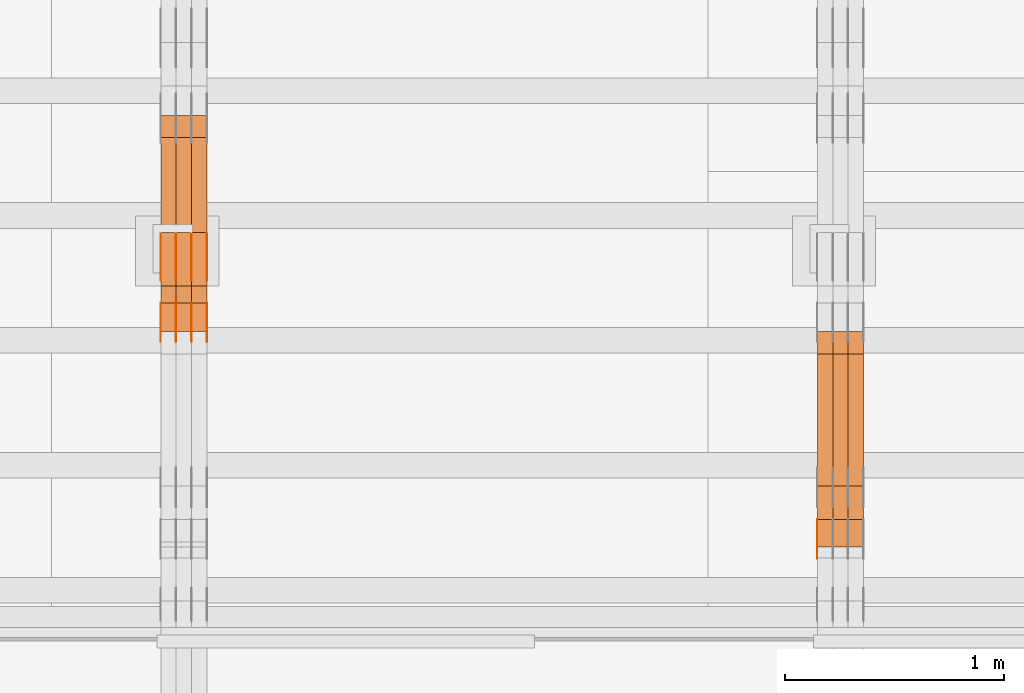
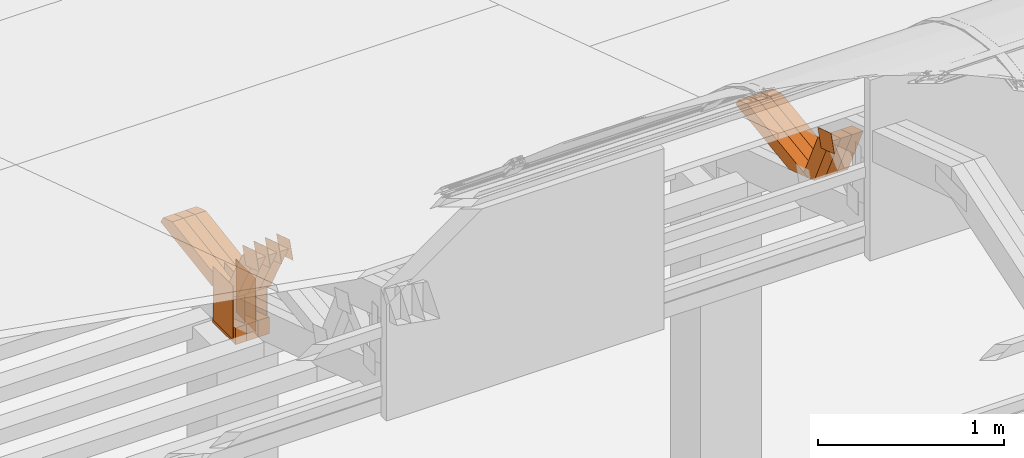
# One storey, part 104 of 385: 28 proxies.
"""IFC2X3 building model written with IfcOpenShell, lengths in millimetres."""

import ifcopenshell
import ifcopenshell.guid

model = None  # the IFC model being written
_history = None  # IfcOwnerHistory: only IFC2X3 demands one
_inside = {}  # id of a spatial element -> (the spatial element, [elements in it])
_under = {}  # id of a project, library or spatial element -> (it, [spatial elements below it])
_declared = {}  # id of a project -> (the project, [libraries it declares])
_typed = {}  # id of a type object -> (the type object, [elements of that type])
_made_of = {}  # id of a material, layer set ... -> (it, [elements and type objects made of it])


def new_model(schema):
    """Start an empty IFC model of exactly this schema.

    Asked for "IFC4X3", IfcOpenShell would pick the latest addendum, in which some entities
    have other attributes; the version numbers below select the first issue.
    IFC2X3 requires an IfcOwnerHistory on every rooted entity: one is made here for all.
    """
    global model, _history
    if schema == "IFC4X3":
        model = ifcopenshell.file(schema_version=(4, 3, 0, 0))
    else:
        model = ifcopenshell.file(schema=schema)
    _inside.clear()
    _under.clear()
    _declared.clear()
    _typed.clear()
    _made_of.clear()
    _history = None
    if model.schema == "IFC2X3":
        org = make("IfcOrganization", Name="unknown")
        user = make(
            "IfcPersonAndOrganization",
            ThePerson=make("IfcPerson", FamilyName="unknown"),
            TheOrganization=org,
        )
        app = make(
            "IfcApplication",
            ApplicationDeveloper=org,
            Version="unknown",
            ApplicationFullName="unknown",
            ApplicationIdentifier="unknown",
        )
        _history = make(
            "IfcOwnerHistory",
            OwningUser=user,
            OwningApplication=app,
            ChangeAction="ADDED",
            CreationDate=0,
        )
    return model


def make(cls, **values):
    """One entity of the class cls with the attributes given. An attribute that is None is left unset."""
    return model.create_entity(
        cls, **{name: value for name, value in values.items() if value is not None}
    )


def entity(cls, *values):
    """Any entity or typed value of the class cls, its attributes in the order of the schema. None: left unset."""
    e = model.create_entity(cls)
    for i, value in enumerate(values):
        if value is not None:
            e[i] = value
    return e


def rooted(cls, **values):
    """An entity with a GlobalId (a new one), such as an element, a storey or a relation."""
    return make(cls, GlobalId=ifcopenshell.guid.new(), OwnerHistory=_history, **values)


def si_unit(unit_type, name, prefix=None):
    """IfcSIUnit, for example si_unit("LENGTHUNIT", "METRE", prefix="MILLI")."""
    return make("IfcSIUnit", UnitType=unit_type, Prefix=prefix, Name=name)


def converted_unit(unit_type, name, factor, base, dimensions=None, offset=None):
    """IfcConversionBasedUnit, such as the inch: factor (a typed value) times the base unit."""
    return make(
        "IfcConversionBasedUnit"
        if offset is None
        else "IfcConversionBasedUnitWithOffset",
        ConversionOffset=offset,
        Dimensions=None
        if dimensions is None
        else entity("IfcDimensionalExponents", *dimensions),
        UnitType=unit_type,
        Name=name,
        ConversionFactor=make(
            "IfcMeasureWithUnit", ValueComponent=factor, UnitComponent=base
        ),
    )


def derived_unit(unit_type, elements):
    """IfcDerivedUnit: a product of units, each with its exponent."""
    return make(
        "IfcDerivedUnit",
        Elements=[
            make("IfcDerivedUnitElement", Unit=unit, Exponent=power)
            for unit, power in elements
        ],
        UnitType=unit_type,
    )


def assignment(units):
    """IfcUnitAssignment: the units of a project."""
    return None if units is None else make("IfcUnitAssignment", Units=units)


def point(xyz):
    """IfcCartesianPoint."""
    return None if xyz is None else make("IfcCartesianPoint", Coordinates=xyz)


def direction(xyz):
    """IfcDirection."""
    return None if xyz is None else make("IfcDirection", DirectionRatios=xyz)


def frame(location, z_axis=None, x_axis=None):
    """IfcAxis2Placement3D, a coordinate frame: its origin and axes. An axis left out is left unset."""
    return make(
        "IfcAxis2Placement3D",
        Location=point(location),
        Axis=direction(z_axis),
        RefDirection=direction(x_axis),
    )


def frame_2d(location, x_axis=None):
    """IfcAxis2Placement2D, a coordinate frame in the plane: its origin and x axis."""
    return make(
        "IfcAxis2Placement2D", Location=point(location), RefDirection=direction(x_axis)
    )


def origin():
    """The frame at (0, 0, 0) with its axes left unset."""
    return frame((0.0, 0.0, 0.0))


def origin_2d_with_axis():
    """The frame at (0, 0) in the plane with the x axis (1, 0) written out."""
    return frame_2d((0.0, 0.0), x_axis=(1.0, 0.0))


def place(relative_to, where):
    """IfcLocalPlacement: puts the frame where relative to a parent placement (None: the world)."""
    return make(
        "IfcLocalPlacement", PlacementRelTo=relative_to, RelativePlacement=where
    )


def context(
    kind, dimensions, precision=None, world=None, true_north=None, identifier=None
):
    """IfcGeometricRepresentationContext, for example the 3D "Model" context."""
    return make(
        "IfcGeometricRepresentationContext",
        ContextIdentifier=identifier,
        ContextType=kind,
        CoordinateSpaceDimension=dimensions,
        Precision=precision,
        WorldCoordinateSystem=world,
        TrueNorth=true_north,
    )


def subcontext(parent, identifier, kind, view, scale=None):
    """IfcGeometricRepresentationSubContext, for example "Body" below "Model"."""
    return make(
        "IfcGeometricRepresentationSubContext",
        ContextIdentifier=identifier,
        ContextType=kind,
        ParentContext=parent,
        TargetScale=scale,
        TargetView=view,
    )


def project(units=None, contexts=None):
    """IfcProject with its units and contexts."""
    return rooted(
        "IfcProject",
        Name="project",
        RepresentationContexts=contexts,
        UnitsInContext=assignment(units),
    )


def spatial(cls, under=None, at=None, **own):
    """A site, building, storey or space (cls), placed at a placement, below another one or the project."""
    s = rooted(cls, ObjectPlacement=at, **own)
    if under is not None:
        _under.setdefault(under.id(), (under, []))[1].append(s)
    return s


def polyline(points):
    """IfcPolyline through the points."""
    return make("IfcPolyline", Points=[point(p) for p in points])


def profile(cls, at=None, kind="AREA", **sizes):
    """A parametric profile (cls). Its sizes go by their IFC names, for example OverallWidth=200.0."""
    return make(cls, ProfileType=kind, Position=at, **sizes)


def rectangle(**sizes):
    """IfcRectangleProfileDef."""
    return profile("IfcRectangleProfileDef", **sizes)


def outline(outer, holes=None, kind="AREA"):
    """IfcArbitraryClosedProfileDef: a profile drawn as a closed curve; with holes, ...WithVoids."""
    if holes is None:
        return make("IfcArbitraryClosedProfileDef", ProfileType=kind, OuterCurve=outer)
    return make(
        "IfcArbitraryProfileDefWithVoids",
        ProfileType=kind,
        OuterCurve=outer,
        InnerCurves=holes,
    )


def extrude(swept, where, along, depth):
    """IfcExtrudedAreaSolid: the profile swept, set in the frame where, extruded along a direction by depth."""
    return make(
        "IfcExtrudedAreaSolid",
        SweptArea=swept,
        Position=where,
        ExtrudedDirection=direction(along),
        Depth=depth,
    )


def shape(context_of_items, identifier, shape_type, items):
    """IfcShapeRepresentation: the items that make up one representation, for example the "Body"."""
    return make(
        "IfcShapeRepresentation",
        ContextOfItems=context_of_items,
        RepresentationIdentifier=identifier,
        RepresentationType=shape_type,
        Items=items,
    )


def source(mapping_origin, context_of_items, identifier, shape_type, items):
    """IfcRepresentationMap: a shape defined once, which mapped items show again and again."""
    return make(
        "IfcRepresentationMap",
        MappingOrigin=mapping_origin,
        MappedRepresentation=shape(context_of_items, identifier, shape_type, items),
    )


def transform(
    local_origin,
    x_axis=None,
    y_axis=None,
    z_axis=None,
    scale=None,
    scale2=None,
    scale3=None,
    uniform=True,
):
    """IfcCartesianTransformationOperator3D, or its non-uniform kind. x_axis, y_axis, z_axis: its Axis1, 2, 3."""
    if uniform:
        return make(
            "IfcCartesianTransformationOperator3D",
            Axis1=direction(x_axis),
            Axis2=direction(y_axis),
            LocalOrigin=point(local_origin),
            Scale=scale,
            Axis3=direction(z_axis),
        )
    return make(
        "IfcCartesianTransformationOperator3DnonUniform",
        Axis1=direction(x_axis),
        Axis2=direction(y_axis),
        LocalOrigin=point(local_origin),
        Scale=scale,
        Axis3=direction(z_axis),
        Scale2=scale2,
        Scale3=scale3,
    )


def mapped(mapping_source, mapping_target):
    """IfcMappedItem: shows the shape of a source again, moved by a transform."""
    return make(
        "IfcMappedItem", MappingSource=mapping_source, MappingTarget=mapping_target
    )


def material(Name=None, Category=None):
    """IfcMaterial."""
    return make("IfcMaterial", Name=Name, Category=Category)


def made_of(thing, what):
    """Note that an element or type object is made of a material, layer set ...; save() writes the relation."""
    if what is not None:
        _made_of.setdefault(what.id(), (what, []))[1].append(thing)
    return thing


def type_object(cls, material=None, **own):
    """A type object (cls), such as IfcWallType, which elements share."""
    return made_of(rooted(cls, **own), material)


def type_shapes(of_type, sources):
    """Give a type object the sources (RepresentationMaps) that its elements show as mapped items."""
    of_type.RepresentationMaps = sources


def element(
    cls,
    number,
    at=None,
    inside=None,
    cuts=None,
    type_object=None,
    material=None,
    context=None,
    identifier="Body",
    shape_type=None,
    held_by="IfcProductDefinitionShape",
    body=None,
    shapes=None,
    **own,
):
    """One element of the class cls, such as IfcWall. Its Tag is "e" and its number.

    at: its placement. inside: the storey or other place that contains it. cuts: it is an
    opening in that element (IfcRelVoidsElement). A single representation is given by context,
    identifier, shape_type and body (its items); several are given by shapes. held_by: the class
    of the entity that holds the representations. save() writes the other relations.
    """
    e = rooted(cls, Tag="e%d" % number, ObjectPlacement=at, **own)
    if body is not None:
        shapes = [shape(context, identifier, shape_type, body)]
    if shapes is not None:
        e.Representation = make(held_by, Representations=shapes)
    if inside is not None:
        _inside.setdefault(inside.id(), (inside, []))[1].append(e)
    if cuts is not None:
        rooted(
            "IfcRelVoidsElement", RelatingBuildingElement=cuts, RelatedOpeningElement=e
        )
    if type_object is not None:
        _typed.setdefault(type_object.id(), (type_object, []))[1].append(e)
    return made_of(e, material)


def aggregate(whole, parts):
    """IfcRelAggregates: a whole, such as a stair, and the parts it consists of."""
    return rooted("IfcRelAggregates", RelatingObject=whole, RelatedObjects=parts)


def save(model, path):
    """Write the relations noted so far, then the file.

    IfcRelAggregates (storeys below a building ...), IfcRelContainedInSpatialStructure (elements
    in a storey), IfcRelDefinesByType, IfcRelAssociatesMaterial and IfcRelDeclares: one each for
    every whole, place, type object, material and project.
    """
    for whole, parts in _under.values():
        aggregate(whole, parts)
    for where, things in _inside.values():
        rooted(
            "IfcRelContainedInSpatialStructure",
            RelatedElements=things,
            RelatingStructure=where,
        )
    for kind, things in _typed.values():
        rooted("IfcRelDefinesByType", RelatedObjects=things, RelatingType=kind)
    for what, things in _made_of.values():
        rooted("IfcRelAssociatesMaterial", RelatedObjects=things, RelatingMaterial=what)
    for by, libraries in _declared.values():
        rooted("IfcRelDeclares", RelatingContext=by, RelatedDefinitions=libraries)
    model.write(path)


model = new_model("IFC2X3")

# Units and contexts
model_context = context("Model", 3, precision=0.01, world=origin(), true_north=direction((6.12303176911189e-17, 1.0)))
body_context = subcontext(model_context, "Body", "Model", "MODEL_VIEW")
ifc_project = project(units=[si_unit("LENGTHUNIT", "METRE", prefix="MILLI"), si_unit("AREAUNIT", "SQUARE_METRE"), si_unit("VOLUMEUNIT", "CUBIC_METRE"), converted_unit("PLANEANGLEUNIT", "DEGREE", entity("IfcRatioMeasure", 0.0174532925199433), si_unit("PLANEANGLEUNIT", "RADIAN"), dimensions=[0, 0, 0, 0, 0, 0, 0]), si_unit("MASSUNIT", "GRAM", prefix="KILO"), derived_unit("MASSDENSITYUNIT", [(si_unit("MASSUNIT", "GRAM", prefix="KILO"), 1), (si_unit("LENGTHUNIT", "METRE"), -3)]), si_unit("TIMEUNIT", "SECOND"), si_unit("FREQUENCYUNIT", "HERTZ"), si_unit("THERMODYNAMICTEMPERATUREUNIT", "DEGREE_CELSIUS"), derived_unit("THERMALTRANSMITTANCEUNIT", [(si_unit("MASSUNIT", "GRAM", prefix="KILO"), 1), (si_unit("THERMODYNAMICTEMPERATUREUNIT", "KELVIN"), -1), (si_unit("TIMEUNIT", "SECOND"), -3)]), derived_unit("VOLUMETRICFLOWRATEUNIT", [(si_unit("LENGTHUNIT", "METRE"), 3), (si_unit("TIMEUNIT", "SECOND"), -1)]), si_unit("ELECTRICCURRENTUNIT", "AMPERE"), si_unit("ELECTRICVOLTAGEUNIT", "VOLT"), si_unit("POWERUNIT", "WATT"), si_unit("FORCEUNIT", "NEWTON", prefix="KILO"), si_unit("ILLUMINANCEUNIT", "LUX"), si_unit("LUMINOUSFLUXUNIT", "LUMEN"), si_unit("LUMINOUSINTENSITYUNIT", "CANDELA"), derived_unit("USERDEFINED", [(si_unit("MASSUNIT", "GRAM", prefix="KILO"), -1), (si_unit("LENGTHUNIT", "METRE"), -2), (si_unit("TIMEUNIT", "SECOND"), 3), (si_unit("LUMINOUSFLUXUNIT", "LUMEN"), 1)]), derived_unit("LINEARVELOCITYUNIT", [(si_unit("LENGTHUNIT", "METRE"), 1), (si_unit("TIMEUNIT", "SECOND"), -1)]), si_unit("PRESSUREUNIT", "PASCAL"), derived_unit("USERDEFINED", [(si_unit("LENGTHUNIT", "METRE"), -2), (si_unit("MASSUNIT", "GRAM", prefix="KILO"), 1), (si_unit("TIMEUNIT", "SECOND"), -2)])], contexts=[model_context])

# Site, building, storey
site_placement = place(None, origin())
site = spatial("IfcSite", under=ifc_project, at=site_placement, CompositionType="ELEMENT")
building_placement = place(site_placement, origin())
building = spatial("IfcBuilding", under=site, at=building_placement, CompositionType="ELEMENT")
storey_placement = place(building_placement, origin())
storey = spatial("IfcBuildingStorey", under=building, at=storey_placement, Name="Default", CompositionType="ELEMENT", Elevation=0.0)

# Proxies
ifc_material_1 = material(Name="IfcSurfaceStyle #200305")
building_element_proxy_type_1 = type_object("IfcBuildingElementProxyType", PredefinedType="NOTDEFINED", material=ifc_material_1)
shared_shape_1 = source(origin(), body_context, "Body", "SweptSolid", [
    extrude(outline(polyline([(-75.0003249421702, -60.0000773549573), (75.0003398116874, -60.0000773549573), (75.0003249421711, 60.0000773549573), (-75.0003398116883, 60.0000773549573), (-75.0003249421702, -60.0000773549573)])), frame((75.0003398116874, 60.0000773549573, 0.0), z_axis=(0.0, 0.0, 1.0), x_axis=(-1.0, 0.0, 0.0)), (0.0, 0.0, 1.0), 1.29999999999999),
])
type_shapes(building_element_proxy_type_1, [shared_shape_1])
proxy_1_placement = place(building_placement, frame((15175.0, 16117.0849050545, 3705.49074668796), z_axis=(-1.0, 0.0, 0.0), x_axis=(0.0, -0.951056516295154, 0.309016994374948)))
element("IfcBuildingElementProxy", 1, at=proxy_1_placement, inside=storey, type_object=building_element_proxy_type_1, material=ifc_material_1, context=body_context, shape_type="MappedRepresentation", body=[
    mapped(shared_shape_1, transform((0.0, 0.0, 0.0), scale=1.0)),
])
ifc_material_2 = material(Name="IfcSurfaceStyle #189970")
building_element_proxy_type_2 = type_object("IfcBuildingElementProxyType", Name="T1-W44 189968", PredefinedType="NOTDEFINED", material=ifc_material_2)
shared_shape_2 = source(origin(), body_context, "Body", "SweptSolid", [
    extrude(outline(polyline([(-184.551057772692, -47.4997984945814), (177.527112951531, -47.4997984945814), (162.630077773546, -0.000452497529500495), (118.068221667048, 47.5000247433462), (-273.674354619433, 47.5000247433462), (-184.551057772692, -47.4997984945814)])), frame((177.527112951531, 47.5002721629815, 0.0), z_axis=(0.0, 0.0, 1.0), x_axis=(-1.0, 0.0, 0.0)), (0.0, 0.0, 1.0), 70.0),
])
type_shapes(building_element_proxy_type_2, [shared_shape_2])
proxy_2_placement = place(building_placement, frame((15385.0, 16220.4899216004, 3388.98238154171), z_axis=(-1.0, 0.0, 0.0), x_axis=(0.0, -0.425335045192995, 0.905035965766374)))
element("IfcBuildingElementProxy", 2, at=proxy_2_placement, inside=storey, type_object=building_element_proxy_type_2, material=ifc_material_2, Name="T1-W44", context=body_context, shape_type="MappedRepresentation", body=[
    mapped(shared_shape_2, transform((0.0, 0.0, 0.0), scale=1.0)),
])
ifc_material_3 = material(Name="IfcSurfaceStyle #189904")
building_element_proxy_type_3 = type_object("IfcBuildingElementProxyType", Name="T1-W44 189902", PredefinedType="NOTDEFINED", material=ifc_material_3)
shared_shape_3 = source(origin(), body_context, "Body", "SweptSolid", [
    extrude(outline(polyline([(-184.551057772692, -47.4997984945814), (177.527112951531, -47.4997984945814), (162.630077773546, -0.000452497529500495), (118.068221667048, 47.5000247433462), (-273.674354619433, 47.5000247433462), (-184.551057772692, -47.4997984945814)])), frame((177.527112951531, 47.5002721629815, 0.0), z_axis=(0.0, 0.0, 1.0), x_axis=(-1.0, 0.0, 0.0)), (0.0, 0.0, 1.0), 70.0),
])
type_shapes(building_element_proxy_type_3, [shared_shape_3])
proxy_3_placement = place(building_placement, frame((15315.0, 16220.4899216004, 3388.98238154171), z_axis=(-1.0, 0.0, 0.0), x_axis=(0.0, -0.425335045192995, 0.905035965766374)))
element("IfcBuildingElementProxy", 3, at=proxy_3_placement, inside=storey, type_object=building_element_proxy_type_3, material=ifc_material_3, Name="T1-W44", context=body_context, shape_type="MappedRepresentation", body=[
    mapped(shared_shape_3, transform((0.0, 0.0, 0.0), scale=1.0)),
])
ifc_material_4 = material(Name="IfcSurfaceStyle #189838")
building_element_proxy_type_4 = type_object("IfcBuildingElementProxyType", Name="T1-W44 189836", PredefinedType="NOTDEFINED", material=ifc_material_4)
shared_shape_4 = source(origin(), body_context, "Body", "SweptSolid", [
    extrude(outline(polyline([(-184.551057772692, -47.4997984945814), (177.527112951531, -47.4997984945814), (162.630077773546, -0.000452497529500495), (118.068221667048, 47.5000247433462), (-273.674354619433, 47.5000247433462), (-184.551057772692, -47.4997984945814)])), frame((177.527112951531, 47.5002721629815, 0.0), z_axis=(0.0, 0.0, 1.0), x_axis=(-1.0, 0.0, 0.0)), (0.0, 0.0, 1.0), 70.0),
])
type_shapes(building_element_proxy_type_4, [shared_shape_4])
proxy_4_placement = place(building_placement, frame((15245.0, 16220.4899216004, 3388.98238154171), z_axis=(-1.0, 0.0, 0.0), x_axis=(0.0, -0.425335045192995, 0.905035965766374)))
element("IfcBuildingElementProxy", 4, at=proxy_4_placement, inside=storey, type_object=building_element_proxy_type_4, material=ifc_material_4, Name="T1-W44", context=body_context, shape_type="MappedRepresentation", body=[
    mapped(shared_shape_4, transform((0.0, 0.0, 0.0), scale=1.0)),
])
ifc_material_5 = material(Name="IfcSurfaceStyle #189574")
building_element_proxy_type_5 = type_object("IfcBuildingElementProxyType", Name="T1-W8 189572", PredefinedType="NOTDEFINED", material=ifc_material_5)
shared_shape_5 = source(origin(), body_context, "Body", "SweptSolid", [
    extrude(outline(polyline([(-476.725263324644, -47.5001051695965), (180.672765845439, -47.5001051695965), (279.11020091716, -1.03605560390907e-06), (296.793624402619, 47.5001056876243), (-279.851327840575, 47.5001056876243), (-476.725263324644, -47.5001051695965)])), frame((296.793624402619, 47.5001056876243, 0.0), z_axis=(0.0, 0.0, 1.0), x_axis=(-1.0, 0.0, 0.0)), (0.0, 0.0, 1.0), 70.0),
])
type_shapes(building_element_proxy_type_5, [shared_shape_5])
proxy_5_placement = place(building_placement, frame((15385.0, 17036.40625, 3432.97192382813), z_axis=(-1.0, 0.0, 0.0), x_axis=(0.0, -0.990844046556832, -0.135011389900564)))
element("IfcBuildingElementProxy", 5, at=proxy_5_placement, inside=storey, type_object=building_element_proxy_type_5, material=ifc_material_5, Name="T1-W8", context=body_context, shape_type="MappedRepresentation", body=[
    mapped(shared_shape_5, transform((0.0, 0.0, 0.0), scale=1.0)),
])
ifc_material_6 = material(Name="IfcSurfaceStyle #189508")
building_element_proxy_type_6 = type_object("IfcBuildingElementProxyType", Name="T1-W8 189506", PredefinedType="NOTDEFINED", material=ifc_material_6)
shared_shape_6 = source(origin(), body_context, "Body", "SweptSolid", [
    extrude(outline(polyline([(-476.725263324644, -47.5001051695965), (180.672765845439, -47.5001051695965), (279.11020091716, -1.03605560390907e-06), (296.793624402619, 47.5001056876243), (-279.851327840575, 47.5001056876243), (-476.725263324644, -47.5001051695965)])), frame((296.793624402619, 47.5001056876243, 0.0), z_axis=(0.0, 0.0, 1.0), x_axis=(-1.0, 0.0, 0.0)), (0.0, 0.0, 1.0), 70.0),
])
type_shapes(building_element_proxy_type_6, [shared_shape_6])
proxy_6_placement = place(building_placement, frame((15315.0, 17036.40625, 3432.97192382813), z_axis=(-1.0, 0.0, 0.0), x_axis=(0.0, -0.990844046556832, -0.135011389900564)))
element("IfcBuildingElementProxy", 6, at=proxy_6_placement, inside=storey, type_object=building_element_proxy_type_6, material=ifc_material_6, Name="T1-W8", context=body_context, shape_type="MappedRepresentation", body=[
    mapped(shared_shape_6, transform((0.0, 0.0, 0.0), scale=1.0)),
])
ifc_material_7 = material(Name="IfcSurfaceStyle #189442")
building_element_proxy_type_7 = type_object("IfcBuildingElementProxyType", Name="T1-W8 189440", PredefinedType="NOTDEFINED", material=ifc_material_7)
shared_shape_7 = source(origin(), body_context, "Body", "SweptSolid", [
    extrude(outline(polyline([(-476.725263324644, -47.5001051695965), (180.672765845439, -47.5001051695965), (279.11020091716, -1.03605560390907e-06), (296.793624402619, 47.5001056876243), (-279.851327840575, 47.5001056876243), (-476.725263324644, -47.5001051695965)])), frame((296.793624402619, 47.5001056876243, 0.0), z_axis=(0.0, 0.0, 1.0), x_axis=(-1.0, 0.0, 0.0)), (0.0, 0.0, 1.0), 70.0),
])
type_shapes(building_element_proxy_type_7, [shared_shape_7])
proxy_7_placement = place(building_placement, frame((15245.0, 17036.40625, 3432.97192382813), z_axis=(-1.0, 0.0, 0.0), x_axis=(0.0, -0.990844046556832, -0.135011389900564)))
element("IfcBuildingElementProxy", 7, at=proxy_7_placement, inside=storey, type_object=building_element_proxy_type_7, material=ifc_material_7, Name="T1-W8", context=body_context, shape_type="MappedRepresentation", body=[
    mapped(shared_shape_7, transform((0.0, 0.0, 0.0), scale=1.0)),
])
ifc_material_8 = material(Name="IfcSurfaceStyle #168210")
building_element_proxy_type_8 = type_object("IfcBuildingElementProxyType", PredefinedType="NOTDEFINED", material=ifc_material_8)
shared_shape_8 = source(origin(), body_context, "Body", "SweptSolid", [
    extrude(rectangle(XDim=350.0, YDim=215.999999999984, at=origin_2d_with_axis()), frame((175.0, 108.0, 0.0), z_axis=(0.0, 0.0, 1.0), x_axis=(-1.0, 0.0, 0.0)), (0.0, 0.0, 1.0), 1.29999999999999),
])
type_shapes(building_element_proxy_type_8, [shared_shape_8])
proxy_8_placement = place(building_placement, frame((12386.3, 17459.2939453125, 3165.36425781251), z_axis=(-1.0, 0.0, 0.0), x_axis=(0.0, 0.0, -1.0)))
element("IfcBuildingElementProxy", 8, at=proxy_8_placement, inside=storey, type_object=building_element_proxy_type_8, material=ifc_material_8, context=body_context, shape_type="MappedRepresentation", body=[
    mapped(shared_shape_8, transform((0.0, 0.0, 0.0), scale=1.0)),
])
ifc_material_9 = material(Name="IfcSurfaceStyle #168153")
building_element_proxy_type_9 = type_object("IfcBuildingElementProxyType", PredefinedType="NOTDEFINED", material=ifc_material_9)
shared_shape_9 = source(origin(), body_context, "Body", "SweptSolid", [
    extrude(rectangle(XDim=350.0, YDim=215.999999999984, at=origin_2d_with_axis()), frame((175.0, 108.0, 0.0), z_axis=(0.0, 0.0, 1.0), x_axis=(-1.0, 0.0, 0.0)), (0.0, 0.0, 1.0), 1.29999999999999),
])
type_shapes(building_element_proxy_type_9, [shared_shape_9])
proxy_9_placement = place(building_placement, frame((12315.0, 17459.2939453125, 3165.36425781251), z_axis=(-1.0, 0.0, 0.0), x_axis=(0.0, 0.0, -1.0)))
element("IfcBuildingElementProxy", 9, at=proxy_9_placement, inside=storey, type_object=building_element_proxy_type_9, material=ifc_material_9, context=body_context, shape_type="MappedRepresentation", body=[
    mapped(shared_shape_9, transform((0.0, 0.0, 0.0), scale=1.0)),
])
ifc_material_10 = material(Name="IfcSurfaceStyle #168096")
building_element_proxy_type_10 = type_object("IfcBuildingElementProxyType", PredefinedType="NOTDEFINED", material=ifc_material_10)
shared_shape_10 = source(origin(), body_context, "Body", "SweptSolid", [
    extrude(rectangle(XDim=350.0, YDim=215.999999999984, at=origin_2d_with_axis()), frame((175.0, 108.0, 0.0), z_axis=(0.0, 0.0, 1.0), x_axis=(-1.0, 0.0, 0.0)), (0.0, 0.0, 1.0), 1.29999999999999),
])
type_shapes(building_element_proxy_type_10, [shared_shape_10])
proxy_10_placement = place(building_placement, frame((12316.3, 17459.2939453125, 3165.36425781251), z_axis=(-1.0, 0.0, 0.0), x_axis=(0.0, 0.0, -1.0)))
element("IfcBuildingElementProxy", 10, at=proxy_10_placement, inside=storey, type_object=building_element_proxy_type_10, material=ifc_material_10, context=body_context, shape_type="MappedRepresentation", body=[
    mapped(shared_shape_10, transform((0.0, 0.0, 0.0), scale=1.0)),
])
ifc_material_11 = material(Name="IfcSurfaceStyle #168039")
building_element_proxy_type_11 = type_object("IfcBuildingElementProxyType", PredefinedType="NOTDEFINED", material=ifc_material_11)
shared_shape_11 = source(origin(), body_context, "Body", "SweptSolid", [
    extrude(rectangle(XDim=350.0, YDim=215.999999999984, at=origin_2d_with_axis()), frame((175.0, 108.0, 0.0), z_axis=(0.0, 0.0, 1.0), x_axis=(-1.0, 0.0, 0.0)), (0.0, 0.0, 1.0), 1.29999999999998),
])
type_shapes(building_element_proxy_type_11, [shared_shape_11])
proxy_11_placement = place(building_placement, frame((12245.0, 17459.2939453125, 3165.36425781251), z_axis=(-1.0, 0.0, 0.0), x_axis=(0.0, 0.0, -1.0)))
element("IfcBuildingElementProxy", 11, at=proxy_11_placement, inside=storey, type_object=building_element_proxy_type_11, material=ifc_material_11, context=body_context, shape_type="MappedRepresentation", body=[
    mapped(shared_shape_11, transform((0.0, 0.0, 0.0), scale=1.0)),
])
ifc_material_12 = material(Name="IfcSurfaceStyle #167982")
building_element_proxy_type_12 = type_object("IfcBuildingElementProxyType", PredefinedType="NOTDEFINED", material=ifc_material_12)
shared_shape_12 = source(origin(), body_context, "Body", "SweptSolid", [
    extrude(rectangle(XDim=350.0, YDim=215.999999999984, at=origin_2d_with_axis()), frame((175.0, 108.0, 0.0), z_axis=(0.0, 0.0, 1.0), x_axis=(-1.0, 0.0, 0.0)), (0.0, 0.0, 1.0), 1.29999999999998),
])
type_shapes(building_element_proxy_type_12, [shared_shape_12])
proxy_12_placement = place(building_placement, frame((12246.3, 17459.2939453125, 3165.36425781251), z_axis=(-1.0, 0.0, 0.0), x_axis=(0.0, 0.0, -1.0)))
element("IfcBuildingElementProxy", 12, at=proxy_12_placement, inside=storey, type_object=building_element_proxy_type_12, material=ifc_material_12, context=body_context, shape_type="MappedRepresentation", body=[
    mapped(shared_shape_12, transform((0.0, 0.0, 0.0), scale=1.0)),
])
ifc_material_13 = material(Name="IfcSurfaceStyle #167925")
building_element_proxy_type_13 = type_object("IfcBuildingElementProxyType", PredefinedType="NOTDEFINED", material=ifc_material_13)
shared_shape_13 = source(origin(), body_context, "Body", "SweptSolid", [
    extrude(rectangle(XDim=350.0, YDim=215.999999999984, at=origin_2d_with_axis()), frame((175.0, 108.0, 0.0), z_axis=(0.0, 0.0, 1.0), x_axis=(-1.0, 0.0, 0.0)), (0.0, 0.0, 1.0), 1.29999999999998),
])
type_shapes(building_element_proxy_type_13, [shared_shape_13])
proxy_13_placement = place(building_placement, frame((12175.0, 17459.2939453125, 3165.36425781251), z_axis=(-1.0, 0.0, 0.0), x_axis=(0.0, 0.0, -1.0)))
element("IfcBuildingElementProxy", 13, at=proxy_13_placement, inside=storey, type_object=building_element_proxy_type_13, material=ifc_material_13, context=body_context, shape_type="MappedRepresentation", body=[
    mapped(shared_shape_13, transform((0.0, 0.0, 0.0), scale=1.0)),
])
ifc_material_14 = material(Name="IfcSurfaceStyle #164790")
building_element_proxy_type_14 = type_object("IfcBuildingElementProxyType", PredefinedType="NOTDEFINED", material=ifc_material_14)
shared_shape_14 = source(origin(), body_context, "Body", "SweptSolid", [
    extrude(outline(polyline([(-74.9998605591058, -59.9999264677524), (74.999875428623, -59.9999264677524), (74.9998605591068, 59.9999264677524), (-74.9998754286239, 59.9999264677524), (-74.9998605591058, -59.9999264677524)])), frame((75.0002460484325, 60.0000016373508, 0.0), z_axis=(0.0, 0.0, 1.0), x_axis=(-1.0, 0.0, 0.0)), (0.0, 0.0, 1.0), 1.3),
])
type_shapes(building_element_proxy_type_14, [shared_shape_14])
proxy_14_placement = place(building_placement, frame((12386.3, 17107.0599369346, 3383.82825001787), z_axis=(-1.0, 0.0, 0.0), x_axis=(0.0, -0.951056516295154, 0.309016994374948)))
element("IfcBuildingElementProxy", 14, at=proxy_14_placement, inside=storey, type_object=building_element_proxy_type_14, material=ifc_material_14, context=body_context, shape_type="MappedRepresentation", body=[
    mapped(shared_shape_14, transform((0.0, 0.0, 0.0), scale=1.0)),
])
ifc_material_15 = material(Name="IfcSurfaceStyle #164733")
building_element_proxy_type_15 = type_object("IfcBuildingElementProxyType", PredefinedType="NOTDEFINED", material=ifc_material_15)
shared_shape_15 = source(origin(), body_context, "Body", "SweptSolid", [
    extrude(outline(polyline([(-74.9998605591058, -59.9999264677524), (74.999875428623, -59.9999264677524), (74.9998605591068, 59.9999264677524), (-74.9998754286239, 59.9999264677524), (-74.9998605591058, -59.9999264677524)])), frame((75.0002460484325, 60.0000016373508, 0.0), z_axis=(0.0, 0.0, 1.0), x_axis=(-1.0, 0.0, 0.0)), (0.0, 0.0, 1.0), 1.3),
])
type_shapes(building_element_proxy_type_15, [shared_shape_15])
proxy_15_placement = place(building_placement, frame((12315.0, 17107.0599369346, 3383.82825001787), z_axis=(-1.0, 0.0, 0.0), x_axis=(0.0, -0.951056516295154, 0.309016994374948)))
element("IfcBuildingElementProxy", 15, at=proxy_15_placement, inside=storey, type_object=building_element_proxy_type_15, material=ifc_material_15, context=body_context, shape_type="MappedRepresentation", body=[
    mapped(shared_shape_15, transform((0.0, 0.0, 0.0), scale=1.0)),
])
ifc_material_16 = material(Name="IfcSurfaceStyle #164676")
building_element_proxy_type_16 = type_object("IfcBuildingElementProxyType", PredefinedType="NOTDEFINED", material=ifc_material_16)
shared_shape_16 = source(origin(), body_context, "Body", "SweptSolid", [
    extrude(outline(polyline([(-74.9998605591058, -59.9999264677524), (74.999875428623, -59.9999264677524), (74.9998605591068, 59.9999264677524), (-74.9998754286239, 59.9999264677524), (-74.9998605591058, -59.9999264677524)])), frame((75.0002460484325, 60.0000016373508, 0.0), z_axis=(0.0, 0.0, 1.0), x_axis=(-1.0, 0.0, 0.0)), (0.0, 0.0, 1.0), 1.3),
])
type_shapes(building_element_proxy_type_16, [shared_shape_16])
proxy_16_placement = place(building_placement, frame((12316.3, 17107.0599369346, 3383.82825001787), z_axis=(-1.0, 0.0, 0.0), x_axis=(0.0, -0.951056516295154, 0.309016994374948)))
element("IfcBuildingElementProxy", 16, at=proxy_16_placement, inside=storey, type_object=building_element_proxy_type_16, material=ifc_material_16, context=body_context, shape_type="MappedRepresentation", body=[
    mapped(shared_shape_16, transform((0.0, 0.0, 0.0), scale=1.0)),
])
ifc_material_17 = material(Name="IfcSurfaceStyle #164619")
building_element_proxy_type_17 = type_object("IfcBuildingElementProxyType", PredefinedType="NOTDEFINED", material=ifc_material_17)
shared_shape_17 = source(origin(), body_context, "Body", "SweptSolid", [
    extrude(outline(polyline([(-74.9998605591058, -59.9999264677524), (74.999875428623, -59.9999264677524), (74.9998605591068, 59.9999264677524), (-74.9998754286239, 59.9999264677524), (-74.9998605591058, -59.9999264677524)])), frame((75.0002460484325, 60.0000016373508, 0.0), z_axis=(0.0, 0.0, 1.0), x_axis=(-1.0, 0.0, 0.0)), (0.0, 0.0, 1.0), 1.29999999999999),
])
type_shapes(building_element_proxy_type_17, [shared_shape_17])
proxy_17_placement = place(building_placement, frame((12245.0, 17107.0599369346, 3383.82825001787), z_axis=(-1.0, 0.0, 0.0), x_axis=(0.0, -0.951056516295154, 0.309016994374948)))
element("IfcBuildingElementProxy", 17, at=proxy_17_placement, inside=storey, type_object=building_element_proxy_type_17, material=ifc_material_17, context=body_context, shape_type="MappedRepresentation", body=[
    mapped(shared_shape_17, transform((0.0, 0.0, 0.0), scale=1.0)),
])
ifc_material_18 = material(Name="IfcSurfaceStyle #164562")
building_element_proxy_type_18 = type_object("IfcBuildingElementProxyType", PredefinedType="NOTDEFINED", material=ifc_material_18)
shared_shape_18 = source(origin(), body_context, "Body", "SweptSolid", [
    extrude(outline(polyline([(-74.9998605591058, -59.9999264677524), (74.999875428623, -59.9999264677524), (74.9998605591068, 59.9999264677524), (-74.9998754286239, 59.9999264677524), (-74.9998605591058, -59.9999264677524)])), frame((75.0002460484325, 60.0000016373508, 0.0), z_axis=(0.0, 0.0, 1.0), x_axis=(-1.0, 0.0, 0.0)), (0.0, 0.0, 1.0), 1.29999999999999),
])
type_shapes(building_element_proxy_type_18, [shared_shape_18])
proxy_18_placement = place(building_placement, frame((12246.3, 17107.0599369346, 3383.82825001787), z_axis=(-1.0, 0.0, 0.0), x_axis=(0.0, -0.951056516295154, 0.309016994374948)))
element("IfcBuildingElementProxy", 18, at=proxy_18_placement, inside=storey, type_object=building_element_proxy_type_18, material=ifc_material_18, context=body_context, shape_type="MappedRepresentation", body=[
    mapped(shared_shape_18, transform((0.0, 0.0, 0.0), scale=1.0)),
])
ifc_material_19 = material(Name="IfcSurfaceStyle #164505")
building_element_proxy_type_19 = type_object("IfcBuildingElementProxyType", PredefinedType="NOTDEFINED", material=ifc_material_19)
shared_shape_19 = source(origin(), body_context, "Body", "SweptSolid", [
    extrude(outline(polyline([(-74.9998605591058, -59.9999264677524), (74.999875428623, -59.9999264677524), (74.9998605591068, 59.9999264677524), (-74.9998754286239, 59.9999264677524), (-74.9998605591058, -59.9999264677524)])), frame((75.0002460484325, 60.0000016373508, 0.0), z_axis=(0.0, 0.0, 1.0), x_axis=(-1.0, 0.0, 0.0)), (0.0, 0.0, 1.0), 1.29999999999999),
])
type_shapes(building_element_proxy_type_19, [shared_shape_19])
proxy_19_placement = place(building_placement, frame((12175.0, 17107.0599369346, 3383.82825001787), z_axis=(-1.0, 0.0, 0.0), x_axis=(0.0, -0.951056516295154, 0.309016994374948)))
element("IfcBuildingElementProxy", 19, at=proxy_19_placement, inside=storey, type_object=building_element_proxy_type_19, material=ifc_material_19, context=body_context, shape_type="MappedRepresentation", body=[
    mapped(shared_shape_19, transform((0.0, 0.0, 0.0), scale=1.0)),
])
ifc_material_20 = material(Name="IfcSurfaceStyle #156501")
building_element_proxy_type_20 = type_object("IfcBuildingElementProxyType", Name="T1-E1 156499", PredefinedType="NOTDEFINED", material=ifc_material_20)
shared_shape_20 = source(origin(), body_context, "Body", "SweptSolid", [
    extrude(outline(polyline([(4.4675903320374, -122.500000000001), (35.3350219726624, -122.500000000001), (35.3350219726501, 122.500000000001), (-75.1376342773499, 122.500000000001), (4.4675903320374, -122.500000000001)])), frame((35.3350219726624, 122.50000005215, 0.0), z_axis=(0.0, 0.0, 1.0), x_axis=(-1.0, 0.0, 0.0)), (0.0, 0.0, 1.0), 70.0),
])
type_shapes(building_element_proxy_type_20, [shared_shape_20])
proxy_20_placement = place(building_placement, frame((12385.0, 17220.0, 2794.30932617186), z_axis=(-1.0, 0.0, 0.0), x_axis=(0.0, 0.0, 1.0)))
element("IfcBuildingElementProxy", 20, at=proxy_20_placement, inside=storey, type_object=building_element_proxy_type_20, material=ifc_material_20, Name="T1-E1", context=body_context, shape_type="MappedRepresentation", body=[
    mapped(shared_shape_20, transform((0.0, 0.0, 0.0), scale=1.0)),
])
ifc_material_21 = material(Name="IfcSurfaceStyle #156444")
building_element_proxy_type_21 = type_object("IfcBuildingElementProxyType", Name="T1-E1 156442", PredefinedType="NOTDEFINED", material=ifc_material_21)
shared_shape_21 = source(origin(), body_context, "Body", "SweptSolid", [
    extrude(outline(polyline([(4.4675903320374, -122.500000000001), (35.3350219726624, -122.500000000001), (35.3350219726501, 122.500000000001), (-75.1376342773499, 122.500000000001), (4.4675903320374, -122.500000000001)])), frame((35.3350219726624, 122.50000005215, 0.0), z_axis=(0.0, 0.0, 1.0), x_axis=(-1.0, 0.0, 0.0)), (0.0, 0.0, 1.0), 70.0),
])
type_shapes(building_element_proxy_type_21, [shared_shape_21])
proxy_21_placement = place(building_placement, frame((12315.0, 17220.0, 2794.30932617186), z_axis=(-1.0, 0.0, 0.0), x_axis=(0.0, 0.0, 1.0)))
element("IfcBuildingElementProxy", 21, at=proxy_21_placement, inside=storey, type_object=building_element_proxy_type_21, material=ifc_material_21, Name="T1-E1", context=body_context, shape_type="MappedRepresentation", body=[
    mapped(shared_shape_21, transform((0.0, 0.0, 0.0), scale=1.0)),
])
ifc_material_22 = material(Name="IfcSurfaceStyle #156387")
building_element_proxy_type_22 = type_object("IfcBuildingElementProxyType", Name="T1-E1 156385", PredefinedType="NOTDEFINED", material=ifc_material_22)
shared_shape_22 = source(origin(), body_context, "Body", "SweptSolid", [
    extrude(outline(polyline([(4.4675903320374, -122.500000000001), (35.3350219726624, -122.500000000001), (35.3350219726501, 122.500000000001), (-75.1376342773499, 122.500000000001), (4.4675903320374, -122.500000000001)])), frame((35.3350219726624, 122.50000005215, 0.0), z_axis=(0.0, 0.0, 1.0), x_axis=(-1.0, 0.0, 0.0)), (0.0, 0.0, 1.0), 70.0),
])
type_shapes(building_element_proxy_type_22, [shared_shape_22])
proxy_22_placement = place(building_placement, frame((12245.0, 17220.0, 2794.30932617186), z_axis=(-1.0, 0.0, 0.0), x_axis=(0.0, 0.0, 1.0)))
element("IfcBuildingElementProxy", 22, at=proxy_22_placement, inside=storey, type_object=building_element_proxy_type_22, material=ifc_material_22, Name="T1-E1", context=body_context, shape_type="MappedRepresentation", body=[
    mapped(shared_shape_22, transform((0.0, 0.0, 0.0), scale=1.0)),
])
ifc_material_23 = material(Name="IfcSurfaceStyle #154746")
building_element_proxy_type_23 = type_object("IfcBuildingElementProxyType", Name="T1-W39 154744", PredefinedType="NOTDEFINED", material=ifc_material_23)
shared_shape_23 = source(origin(), body_context, "Body", "SweptSolid", [
    extrude(outline(polyline([(-191.519946663886, -47.499928106579), (188.32936223763, -47.499928106579), (171.597440144109, 0.000249483340993841), (122.102882529753, 47.4998033649085), (-290.509738247605, 47.4998033649085), (-191.519946663886, -47.499928106579)])), frame((188.329593252001, 47.499957247623, 0.0), z_axis=(0.0, 0.0, 1.0), x_axis=(-1.0, 0.0, 0.0)), (0.0, 0.0, 1.0), 70.0),
])
type_shapes(building_element_proxy_type_23, [shared_shape_23])
proxy_23_placement = place(building_placement, frame((12385.0, 17238.5876916597, 3055.56121424762), z_axis=(-1.0, 0.0, 0.0), x_axis=(0.0, -0.472216932390777, 0.881482370080902)))
element("IfcBuildingElementProxy", 23, at=proxy_23_placement, inside=storey, type_object=building_element_proxy_type_23, material=ifc_material_23, Name="T1-W39", context=body_context, shape_type="MappedRepresentation", body=[
    mapped(shared_shape_23, transform((0.0, 0.0, 0.0), scale=1.0)),
])
ifc_material_24 = material(Name="IfcSurfaceStyle #154680")
building_element_proxy_type_24 = type_object("IfcBuildingElementProxyType", Name="T1-W39 154678", PredefinedType="NOTDEFINED", material=ifc_material_24)
shared_shape_24 = source(origin(), body_context, "Body", "SweptSolid", [
    extrude(outline(polyline([(-191.519946663886, -47.499928106579), (188.32936223763, -47.499928106579), (171.597440144109, 0.000249483340993841), (122.102882529753, 47.4998033649085), (-290.509738247605, 47.4998033649085), (-191.519946663886, -47.499928106579)])), frame((188.329593252001, 47.499957247623, 0.0), z_axis=(0.0, 0.0, 1.0), x_axis=(-1.0, 0.0, 0.0)), (0.0, 0.0, 1.0), 70.0),
])
type_shapes(building_element_proxy_type_24, [shared_shape_24])
proxy_24_placement = place(building_placement, frame((12315.0, 17238.5876916597, 3055.56121424762), z_axis=(-1.0, 0.0, 0.0), x_axis=(0.0, -0.472216932390777, 0.881482370080902)))
element("IfcBuildingElementProxy", 24, at=proxy_24_placement, inside=storey, type_object=building_element_proxy_type_24, material=ifc_material_24, Name="T1-W39", context=body_context, shape_type="MappedRepresentation", body=[
    mapped(shared_shape_24, transform((0.0, 0.0, 0.0), scale=1.0)),
])
ifc_material_25 = material(Name="IfcSurfaceStyle #154614")
building_element_proxy_type_25 = type_object("IfcBuildingElementProxyType", Name="T1-W39 154612", PredefinedType="NOTDEFINED", material=ifc_material_25)
shared_shape_25 = source(origin(), body_context, "Body", "SweptSolid", [
    extrude(outline(polyline([(-191.519946663886, -47.499928106579), (188.32936223763, -47.499928106579), (171.597440144109, 0.000249483340993841), (122.102882529753, 47.4998033649085), (-290.509738247605, 47.4998033649085), (-191.519946663886, -47.499928106579)])), frame((188.329593252001, 47.499957247623, 0.0), z_axis=(0.0, 0.0, 1.0), x_axis=(-1.0, 0.0, 0.0)), (0.0, 0.0, 1.0), 70.0),
])
type_shapes(building_element_proxy_type_25, [shared_shape_25])
proxy_25_placement = place(building_placement, frame((12245.0, 17238.5876916597, 3055.56121424762), z_axis=(-1.0, 0.0, 0.0), x_axis=(0.0, -0.472216932390777, 0.881482370080902)))
element("IfcBuildingElementProxy", 25, at=proxy_25_placement, inside=storey, type_object=building_element_proxy_type_25, material=ifc_material_25, Name="T1-W39", context=body_context, shape_type="MappedRepresentation", body=[
    mapped(shared_shape_25, transform((0.0, 0.0, 0.0), scale=1.0)),
])
ifc_material_26 = material(Name="IfcSurfaceStyle #154350")
building_element_proxy_type_26 = type_object("IfcBuildingElementProxyType", Name="T1-W10 154348", PredefinedType="NOTDEFINED", material=ifc_material_26)
shared_shape_26 = source(origin(), body_context, "Body", "SweptSolid", [
    extrude(outline(polyline([(-459.546036710757, -47.5000436364511), (174.689450869018, -47.5000436364511), (268.831081103959, 0.00011114562912502), (287.286350706789, 47.4999880636365), (-271.260845969009, 47.4999880636366), (-459.546036710757, -47.5000436364511)])), frame((287.286768781132, 47.5001637448091, 0.0), z_axis=(0.0, 0.0, 1.0), x_axis=(-1.0, 0.0, 0.0)), (0.0, 0.0, 1.0), 70.0),
])
type_shapes(building_element_proxy_type_26, [shared_shape_26])
proxy_26_placement = place(building_placement, frame((12385.0, 18025.1410649788, 3112.76453857986), z_axis=(-1.0, 0.0, 0.0), x_axis=(0.0, -0.988299196256916, -0.152527698068035)))
element("IfcBuildingElementProxy", 26, at=proxy_26_placement, inside=storey, type_object=building_element_proxy_type_26, material=ifc_material_26, Name="T1-W10", context=body_context, shape_type="MappedRepresentation", body=[
    mapped(shared_shape_26, transform((0.0, 0.0, 0.0), scale=1.0)),
])
ifc_material_27 = material(Name="IfcSurfaceStyle #154284")
building_element_proxy_type_27 = type_object("IfcBuildingElementProxyType", Name="T1-W10 154282", PredefinedType="NOTDEFINED", material=ifc_material_27)
shared_shape_27 = source(origin(), body_context, "Body", "SweptSolid", [
    extrude(outline(polyline([(-459.546036710757, -47.5000436364511), (174.689450869018, -47.5000436364511), (268.831081103959, 0.00011114562912502), (287.286350706789, 47.4999880636365), (-271.260845969009, 47.4999880636366), (-459.546036710757, -47.5000436364511)])), frame((287.286768781132, 47.5001637448091, 0.0), z_axis=(0.0, 0.0, 1.0), x_axis=(-1.0, 0.0, 0.0)), (0.0, 0.0, 1.0), 70.0),
])
type_shapes(building_element_proxy_type_27, [shared_shape_27])
proxy_27_placement = place(building_placement, frame((12315.0, 18025.1410649788, 3112.76453857986), z_axis=(-1.0, 0.0, 0.0), x_axis=(0.0, -0.988299196256916, -0.152527698068035)))
element("IfcBuildingElementProxy", 27, at=proxy_27_placement, inside=storey, type_object=building_element_proxy_type_27, material=ifc_material_27, Name="T1-W10", context=body_context, shape_type="MappedRepresentation", body=[
    mapped(shared_shape_27, transform((0.0, 0.0, 0.0), scale=1.0)),
])
ifc_material_28 = material(Name="IfcSurfaceStyle #154218")
building_element_proxy_type_28 = type_object("IfcBuildingElementProxyType", Name="T1-W10 154216", PredefinedType="NOTDEFINED", material=ifc_material_28)
shared_shape_28 = source(origin(), body_context, "Body", "SweptSolid", [
    extrude(outline(polyline([(-459.546036710757, -47.5000436364511), (174.689450869018, -47.5000436364511), (268.831081103959, 0.00011114562912502), (287.286350706789, 47.4999880636365), (-271.260845969009, 47.4999880636366), (-459.546036710757, -47.5000436364511)])), frame((287.286768781132, 47.5001637448091, 0.0), z_axis=(0.0, 0.0, 1.0), x_axis=(-1.0, 0.0, 0.0)), (0.0, 0.0, 1.0), 70.0),
])
type_shapes(building_element_proxy_type_28, [shared_shape_28])
proxy_28_placement = place(building_placement, frame((12245.0, 18025.1410649788, 3112.76453857986), z_axis=(-1.0, 0.0, 0.0), x_axis=(0.0, -0.988299196256916, -0.152527698068035)))
element("IfcBuildingElementProxy", 28, at=proxy_28_placement, inside=storey, type_object=building_element_proxy_type_28, material=ifc_material_28, Name="T1-W10", context=body_context, shape_type="MappedRepresentation", body=[
    mapped(shared_shape_28, transform((0.0, 0.0, 0.0), scale=1.0)),
])

save(model, "model.ifc")
